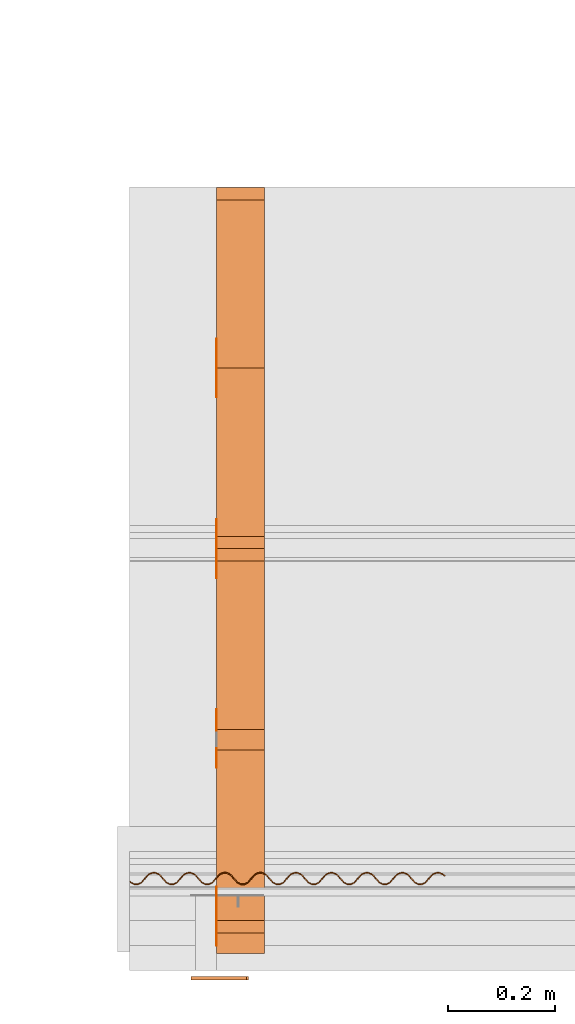
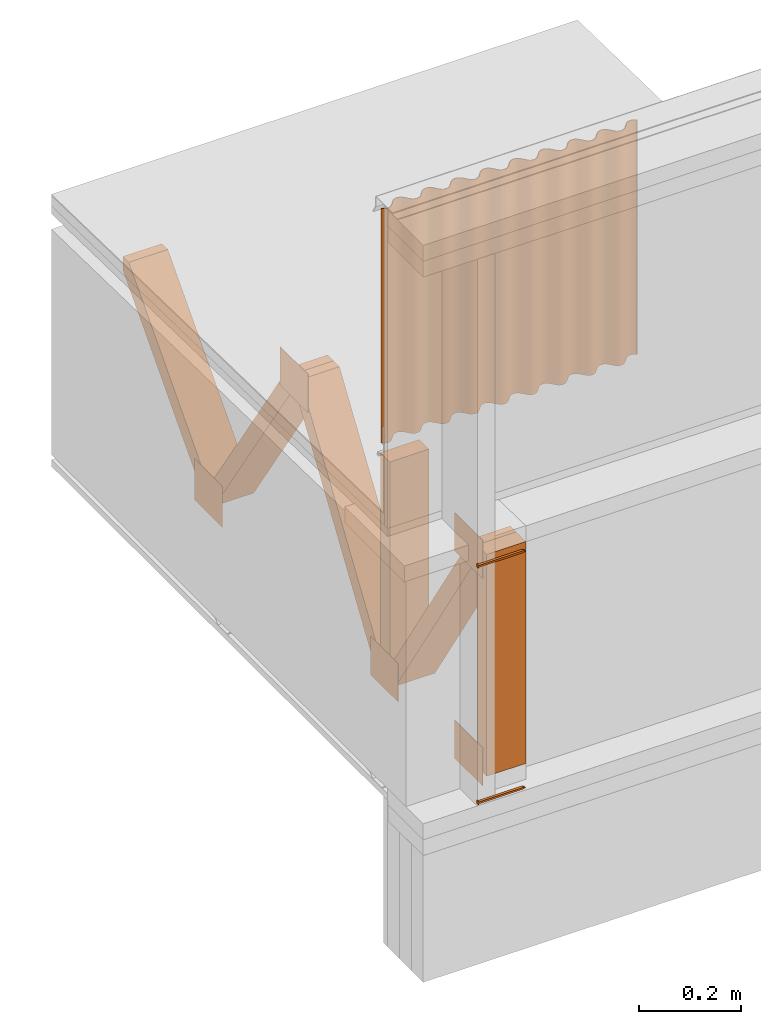
# One storey, part 14 of 22: 14 proxies.
"""IFC2X3 building model written with IfcOpenShell, lengths in feet."""

from ifc_helpers import new_model, entity, si_unit, converted_unit, frame, frame_2d, origin_with_axes, place, context, subcontext, project, spatial, polyline, rectangle, outline, extrude, source, transform, mapped, type_object, type_shapes, element, save


model = new_model("IFC2X3")

# Units and contexts
model_context = context("Model", 3, precision=1e-05)
plan_context = context("Plan", 2, precision=1e-05, world=frame_2d((0.0, 0.0, 0.0), x_axis=(1.0, 0.0, 0.0)))
body_context_1 = subcontext(model_context, "Body", "Model", "MODEL_VIEW")
body_context_2 = subcontext(model_context, "Body", "Model", "MODEL_VIEW")
ifc_project = project(units=[converted_unit("VOLUMEUNIT", "cubic foot", entity("IfcReal", 0.0283168467116885), si_unit("VOLUMEUNIT", "CUBIC_METRE"), dimensions=[3, 0, 0, 0, 0, 0, 0]), converted_unit("AREAUNIT", "square foot", entity("IfcReal", 0.09290304), si_unit("AREAUNIT", "SQUARE_METRE"), dimensions=[2, 0, 0, 0, 0, 0, 0]), converted_unit("LENGTHUNIT", "foot", entity("IfcReal", 0.3048), si_unit("LENGTHUNIT", "METRE"), dimensions=[1, 0, 0, 0, 0, 0, 0])], contexts=[model_context, plan_context])

# Site, building, storey
site_placement = place(None, origin_with_axes())
site = spatial("IfcSite", under=ifc_project, at=site_placement, CompositionType="ELEMENT")
building_placement = place(site_placement, origin_with_axes())
building = spatial("IfcBuilding", under=site, at=building_placement, Name="Building", CompositionType="ELEMENT")
storey_placement = place(building_placement, origin_with_axes())
storey = spatial("IfcBuildingStorey", under=building, at=storey_placement, Name="Storey", CompositionType="ELEMENT")

# Proxies
building_element_proxy_type = type_object("IfcBuildingElementProxyType", PredefinedType="NOTDEFINED")
shared_shape = source(origin_with_axes(), body_context_1, "Body", "SweptSolid", [
    extrude(outline(polyline([(0.118784633345335, 3.75537964679768e-09), (0.115601355674386, 0.0273151472308661), (0.10877257344995, 0.0265193217020883), (0.109568402034248, 0.019690537949892), (-0.221524240933065, -0.0188947170043946), (-0.234386001241802, -0.0273151411198256), (-0.219932583764469, -0.0325522875643074), (0.111160034758682, 0.0060329681538593), (0.111955851120899, -0.000795817269324606), (0.118784633345335, 3.75537964679768e-09)])), frame((0.111111134212474, 6.6839505642105e-10, -0.0200000086804153), z_axis=(-4.82754742847646e-08, 0.0, -1.0), x_axis=(-0.993277668952942, -0.115755714476109, 5.14463884826455e-08)), (-8.28972535060757e-09, 7.11323480118153e-08, -0.999999940395355), 0.0199999997321789),
])
type_shapes(building_element_proxy_type, [shared_shape])
for number, where, z_axis, x_axis in (
    (1, (1675.26345240475, 0.883739177636274, -61.5758282618886), (-3.25841426729312e-07, 1.0, -1.94707183709397e-07), (1.0, 3.25841369885893e-07, -3.25841369885893e-07)),
    (2, (1675.26345240475, 0.883739177636274, -59.7100558243399), (-3.25841426729312e-07, 1.0, -1.94707183709397e-07), (1.0, 3.25841369885893e-07, -3.25841369885893e-07)),
):
    element("IfcBuildingElementProxy", number, at=place(storey_placement, frame(where, z_axis=z_axis, x_axis=x_axis)), inside=storey, type_object=building_element_proxy_type, context=body_context_1, shape_type="MappedRepresentation", body=[
        mapped(shared_shape, transform((0.0, 0.0, 0.0), x_axis=(1.0, 0.0, 0.0), y_axis=(0.0, 1.0, 0.0), z_axis=(0.0, 0.0, 1.0), scale=1.0)),
    ])
proxy_1_placement = place(storey_placement, frame((1675.4142380762, 4.92389902980935, -61.9758708583401), z_axis=(0.0, 0.0, 1.0), x_axis=(-4.37113882867379e-08, -1.0, 0.0)))
element("IfcBuildingElementProxy", 3, at=proxy_1_placement, inside=storey, Name="Generic Models 855:Generic Models 1", context=body_context_1, shape_type="SweptSolid", body=[
    extrude(outline(polyline([(-0.83499908290823, -0.554330822989697), (-0.726033657241681, -0.554330822989697), (0.834998691801637, 0.478032575504673), (0.834998691801637, 0.55433121409629), (0.726033461688385, 0.55433121409629), (-0.834998985131582, -0.478032379951377), (-0.83499908290823, -0.554330822989697)])), frame((1.96849052205173, 2.46049200261872e-07, 1.29333396596233), z_axis=(0.0, -1.0, 0.0), x_axis=(0.0, 0.0, 1.0)), (0.0, 0.0, -1.0), 0.291666664589754),
])
proxy_2_placement = place(storey_placement, frame((1675.4142380762, 4.92389902980935, -61.9758708583401), z_axis=(0.0, 0.0, 1.0), x_axis=(-4.37113882867379e-08, -1.0, 0.0)))
element("IfcBuildingElementProxy", 4, at=proxy_2_placement, inside=storey, Name="Generic Models 855:Generic Models 1", context=body_context_1, shape_type="SweptSolid", body=[
    extrude(outline(polyline([(-0.960161308134635, -0.06187384522806), (0.911361178544563, -0.0618737718955738), (1.0022490708221, -0.00176660403648386), (0.960161308134635, 0.0618739185605462), (-0.911361374097859, 0.0618737474514118), (-1.00224897304545, 0.00176672625729418), (-0.960161308134635, -0.06187384522806)])), frame((0.859770405636685, 2.21605038198473e-07, 1.29333445484557), z_axis=(1.26844657000191e-09, -1.0, -3.13384731498445e-08), x_axis=(-0.551616966724396, 2.54396539389745e-08, -0.834097564220428)), (-1.42177441375679e-07, 1.83448563007005e-08, -1.0), 0.291666664589757),
])
proxy_3_placement = place(storey_placement, frame((1675.4142380762, 7.14122936168681, -61.9758708583401), z_axis=(0.0, 0.0, 1.0), x_axis=(-4.37113882867379e-08, -1.0, 0.0)))
element("IfcBuildingElementProxy", 5, at=proxy_3_placement, inside=storey, Name="Generic Models 855:Generic Models 1", context=body_context_1, shape_type="SweptSolid", body=[
    extrude(outline(polyline([(-0.554331018542993, -0.624998895514981), (-0.478032379951377, -0.624998895514981), (0.554331018542993, 0.516033567625081), (0.554331018542993, 0.62499899329163), (0.478032575504673, 0.624998944403305), (-0.554331018542993, -0.516033665401729), (-0.554331018542993, -0.624998895514981)])), frame((1.96849032649844, 0.291666910638959, 1.08333377856908), z_axis=(0.0, 1.0, 0.0), x_axis=(1.0, 0.0, 0.0)), (0.0, -3.35234233261872e-07, -1.0), 0.291666664589771),
])
proxy_4_placement = place(storey_placement, frame((1675.4142380762, 6.03256419574808, -61.8508731912127), z_axis=(0.0, 0.0, 1.0), x_axis=(-4.37113882867379e-08, -1.0, 0.0)))
element("IfcBuildingElementProxy", 6, at=proxy_4_placement, inside=storey, Name="Generic Models 855:Generic Models 1", context=body_context_1, shape_type="SweptSolid", body=[
    extrude(rectangle(XDim=0.124999233345449, YDim=0.291669311091376, at=frame_2d((0.0, 0.0, 0.0))), frame((3.69392433191535, 0.145834848636717, 0.333333109307477), z_axis=(-1.56443593368749e-06, 0.0, -1.0), x_axis=(0.999999940395355, 0.0, -1.56443593368749e-06)), (-9.58482360147173e-07, 0.0, -1.0), 1.72116860376226),
])
proxy_5_placement = place(storey_placement, frame((1675.4142380762, 4.78252494741925, -61.8508731912127), z_axis=(0.0, 0.0, 1.0), x_axis=(-4.37113882867379e-08, -1.0, 0.0)))
element("IfcBuildingElementProxy", 7, at=proxy_5_placement, inside=storey, Name="Generic Models 855:Generic Models 1", context=body_context_1, shape_type="SweptSolid", body=[
    extrude(rectangle(XDim=0.124999233345449, YDim=0.291669311091376, at=frame_2d((0.0, 0.0, 0.0))), frame((3.69392433191535, 0.145834848636717, 0.333333109307477), z_axis=(-1.56443593368749e-06, 0.0, -1.0), x_axis=(-0.999999940395355, 0.0, 1.56443593368749e-06)), (9.68473727880337e-07, 0.0, -1.0), 1.75002364560732),
])
proxy_6_placement = place(storey_placement, frame((1675.41143462414, 4.67839672809511, -61.4758739321251), z_axis=(0.0, 0.0, 1.0), x_axis=(-4.37113882867379e-08, -1.0, 0.0)))
element("IfcBuildingElementProxy", 8, at=proxy_6_placement, inside=storey, Name="Generic Models 852:Generic Models 1", context=body_context_1, shape_type="SweptSolid", body=[
    extrude(rectangle(XDim=0.360930176725411, YDim=0.00277022707595213, at=frame_2d((0.0, 0.0, 0.0))), frame((3.42311743363308, 0.00138511354766121, 1.4904025071875), z_axis=(0.0, 0.0, -1.0), x_axis=(1.0, 0.0, 0.0)), (0.0, 0.0, -1.0), 0.301264218204712),
])
proxy_7_placement = place(storey_placement, frame((1675.41143462414, 4.79884504333256, -61.6217035008228), z_axis=(0.0, 0.0, 1.0), x_axis=(-4.37113882867379e-08, -1.0, 0.0)))
element("IfcBuildingElementProxy", 9, at=proxy_7_placement, inside=storey, Name="Generic Models 852:Generic Models 1", context=body_context_1, shape_type="SweptSolid", body=[
    extrude(rectangle(XDim=0.360930148950862, YDim=0.00277022707595213, at=frame_2d((0.0, 0.0, 0.0))), frame((0.180465076363149, 0.00138511354766121, 0.0), z_axis=(0.0, 0.0, -1.0), x_axis=(-1.0, 0.0, 0.0)), (0.0, 0.0, -1.0), 0.322097519461289),
])
proxy_8_placement = place(storey_placement, frame((1675.41143462414, 4.74287612544583, -61.6217035008228), z_axis=(0.0, 0.0, 1.0), x_axis=(-4.37113882867379e-08, -1.0, 0.0)))
element("IfcBuildingElementProxy", 10, at=proxy_8_placement, inside=storey, Name="Generic Models 852:Generic Models 1", context=body_context_1, shape_type="SweptSolid", body=[
    extrude(rectangle(XDim=0.360929982303518, YDim=0.00277022707595213, at=frame_2d((0.0, 0.0, 0.0))), frame((2.39778886942726, 0.00138511354766121, 0.0), z_axis=(0.0, 0.0, -1.0), x_axis=(1.0, 0.0, 0.0)), (0.0, 0.0, -1.0), 0.301264184929359),
])
proxy_9_placement = place(storey_placement, frame((1675.41143462414, 4.79884504333256, -61.5350405375163), z_axis=(0.0, 0.0, 1.0), x_axis=(-4.37113882867379e-08, -1.0, 0.0)))
element("IfcBuildingElementProxy", 11, at=proxy_9_placement, inside=storey, Name="Generic Models 852:Generic Models 1", context=body_context_1, shape_type="SweptSolid", body=[
    extrude(rectangle(XDim=0.360930176725411, YDim=0.00277022707595213, at=frame_2d((0.0, 0.0, 0.0))), frame((1.28912702789457, 0.00138511354766121, 1.4904025071875), z_axis=(0.0, 0.0, -1.0), x_axis=(1.0, 0.0, 0.0)), (0.0, 0.0, -1.0), 0.301264218204712),
])
proxy_10_placement = place(storey_placement, frame((1675.41143462414, 3.65313426090351, -61.6217035008228), z_axis=(0.0, 0.0, 1.0), x_axis=(-4.37113882867379e-08, -1.0, 0.0)))
element("IfcBuildingElementProxy", 12, at=proxy_10_placement, inside=storey, Name="Generic Models 852:Generic Models 1", context=body_context_1, shape_type="SweptSolid", body=[
    extrude(rectangle(XDim=0.360929982303518, YDim=0.00277022707595213, at=frame_2d((0.0, 0.0, 0.0))), frame((2.39778886942726, 0.00138511354766121, 0.0), z_axis=(0.0, 0.0, -1.0), x_axis=(-1.0, 0.0, 0.0)), (0.0, 0.0, -1.0), 0.301264184929359),
])
proxy_11_placement = place(storey_placement, frame((1675.4142380762, 2.70656889348518, -61.9758708583401), z_axis=(0.0, 0.0, 1.0), x_axis=(-4.37113882867379e-08, -1.0, 0.0)))
element("IfcBuildingElementProxy", 13, at=proxy_11_placement, inside=storey, Name="Generic Models 855:Generic Models 1", context=body_context_1, shape_type="SweptSolid", body=[
    extrude(outline(polyline([(-0.999140653397467, -0.0614843519497418), (0.948410510547518, -0.0614845475030383), (1.04022757431341, -0.00280711868303654), (0.999140848950764, 0.0614841563964453), (-0.948410314994221, 0.0614846208355245), (-1.04022737876011, 0.0028069475739021), (-0.999140653397467, -0.0614843519497418)])), frame((0.99294943603005, 2.20078280475601e-07, 1.33334553930077), z_axis=(3.70475894406752e-09, -1.0, -2.96324760284961e-08), x_axis=(0.538498640060425, -2.29741878854384e-08, 0.842626452445984)), (4.79877144243801e-07, -3.54313016259766e-07, -1.0), 0.291666664589806),
])
proxy_12_placement = place(storey_placement, frame((1674.88038070559, 1.46614148078628, -57.0275777281113), z_axis=(-8.02678641775856e-07, 5.64259664770361e-07, 1.0), x_axis=(3.13916473260178e-07, -1.0, 5.64259892144037e-07)))
element("IfcBuildingElementProxy", 14, at=proxy_12_placement, inside=storey, Name="Generic Models 1:Generic Models 1", context=body_context_2, shape_type="SweptSolid", body=[
    extrude(outline(polyline([(0.135952978348482, -4.94134916711276e-09), (0.1248598387196, -0.00656200398683665), (0.0891126411187211, -0.0342203480169529), (0.0780221842366254, -0.0406805550547566), (0.0656541837794887, -0.0443130033701815), (0.0527797858389657, -0.0447688106046574), (0.0401728589752606, -0.0421088763324451), (0.0285739513001652, -0.036489438470893), (0.0187218203905999, -0.0281687373701199), (0.0112109497957068, -0.017783858170464), (-0.0103215581255909, 0.0219600027050637), (-0.017823781598154, 0.0324454115767257), (-0.0276493753142792, 0.0408628382267836), (-0.0392359661872149, 0.0464796636185152), (-0.0518613758929602, 0.0491435059011374), (-0.0647420193168904, 0.0486890492066154), (-0.0771181780131157, 0.0449559764980566), (-0.0882172759065008, 0.0383952703434495), (-0.123976610033844, 0.0107394448259058), (-0.135060998652707, 0.0042779663097348), (-0.147422692516032, 0.000644179533209451), (-0.160290979416039, 0.000187101178434971), (-0.172910278081268, 0.00284965095211681), (-0.184509130756999, 0.00846906417853681), (-0.194355202569893, 0.0167884888357221), (-0.201872185733062, 0.0271746880201295), (-0.223404632543954, 0.0669185213959749), (-0.230913121360806, 0.0774052502523883), (-0.240738525634676, 0.0858226219030816), (-0.252319142965507, 0.0914381731428656), (-0.264944454894604, 0.0941020001478865), (-0.277824963875643, 0.0936475098426417), (-0.2902012631258, 0.0899144829668867), (-0.301300257131496, 0.0833537615346783), (-0.337065855075368, 0.0556992498908456), (-0.348144291540769, 0.0492365067712278), (-0.360505924293688, 0.045602744582092), (-0.373374064528723, 0.0451456173628647), (-0.385999523122792, 0.0478094627010071), (-0.397579993788652, 0.0534249894966291), (-0.407438495457955, 0.0617470228042346), (-0.414949233137716, 0.0721319233925324), (-0.436487864321611, 0.111877067586568), (-0.443996328694301, 0.122363784220901), (-0.453815597483492, 0.130779872553086), (-0.465408534672004, 0.136398020985089), (-0.478015513479553, 0.139057973590423), (-0.490895924683944, 0.138603458841016), (-0.503284421570971, 0.134872998602278), (-0.514383440020829, 0.128312295503191), (-0.550143049144995, 0.100656524985012), (-0.561221338945424, 0.094193757421232), (-0.573583045030829, 0.0905599677324139), (-0.586463407346896, 0.0901054346498855), (-0.599082706012125, 0.0927680027805601), (-0.610669483271796, 0.0983848495609335), (-0.620515542862609, 0.106704255121117), (-0.628044735884729, 0.117093023998061), (-0.649571047210944, 0.156835589333), (-0.657073449431442, 0.167321022648824), (-0.666904940301665, 0.175739689840107), (-0.678485557632496, 0.181355259413012), (-0.691092634216694, 0.184015224240427), (-0.7039791564616, 0.183561992809528), (-0.716373764389143, 0.179832840333461), (-0.727466574021837, 0.173270805027541), (-0.763220072105488, 0.145613751190854), (-0.774298459682565, 0.139150995849155), (-0.786666227920162, 0.135518495589886), (-0.799546639124552, 0.135063968618398), (-0.812159826749266, 0.137725228986402), (-0.823752617272805, 0.143343365196324), (-0.833598627975294, 0.15166278908963), (-0.841121758845222, 0.162050262425985), (-0.862660292252468, 0.201795406620021), (-0.870162694472966, 0.212280852157926), (-0.879975852221642, 0.22069563272744), (-0.891562580592989, 0.226312461174692), (-0.904181928146543, 0.228975041527448), (-0.917062339350933, 0.228520526778041), (-0.929456898390152, 0.224791349857811), (-0.94054359698233, 0.218228043455464), (-0.937370744746501, 0.214079453602551), (-0.927388433396347, 0.219954852396109), (-0.916226251231717, 0.223330053405499), (-0.90461146096232, 0.223846949656492), (-0.893259689876727, 0.221451837325034), (-0.882837676939376, 0.216285417007962), (-0.874002970109774, 0.208691006961457), (-0.867232817208047, 0.199281006777693), (-0.845665146359621, 0.159734385845855), (-0.837418174962672, 0.148170891650549), (-0.826593908894406, 0.139031133900477), (-0.813865393713078, 0.132764078520258), (-0.799990789549244, 0.129836670115707), (-0.785815326638735, 0.13042725329324), (-0.772215279303198, 0.134413705019187), (-0.760005615905827, 0.141661056852716), (-0.724281401928328, 0.169119624093449), (-0.71430520161869, 0.174996306205515), (-0.703142921677412, 0.178371494992824), (-0.691534438001828, 0.17888973567273), (-0.68018261802791, 0.176494611119191), (-0.66975468960334, 0.171326919705693), (-0.660919640555469, 0.163732460770864), (-0.654149536542066, 0.154322472809181), (-0.632581914581965, 0.114775827433181), (-0.624341054225531, 0.103213641000545), (-0.613504517187909, 0.0940713043913754), (-0.600782161935421, 0.087805538440705), (-0.586913815477076, 0.0848794377988248), (-0.572732192637726, 0.0854687193247277), (-0.559132145302189, 0.089455183272756), (-0.546928690721982, 0.0967038245358336), (-0.511198121262348, 0.124161065680774), (-0.501222018729358, 0.130037760014922), (-0.490071911980787, 0.133415552105491), (-0.478457415041335, 0.133932485022726), (-0.467087115280897, 0.131533461625338), (-0.456677617754523, 0.126369669055688), (-0.447842519818328, 0.118775185676697), (-0.441066402541058, 0.109363938840668), (-0.419504891621472, 0.0698186073383791), (-0.411257920224523, 0.0582551314761945), (-0.400427567559903, 0.0491140873520941), (-0.387711225571282, 0.0428495986088915), (-0.373830510366933, 0.0399208885527111), (-0.359655096344748, 0.0405114778412843), (-0.346048913524533, 0.044496643193203), (-0.333845312279353, 0.051745266123159), (-0.298121122746017, 0.0792038394749321), (-0.288151057921057, 0.0850818293496692), (-0.276982666939262, 0.0884557287074293), (-0.265368072223163, 0.0889726677357055), (-0.254010092320405, 0.0865762354194961), (-0.243594385976866, 0.0814111411982165), (-0.234765594634484, 0.0738179839150173), (-0.227989355136403, 0.0644067248569073), (-0.206427819772655, 0.0248613841880572), (-0.198174639558542, 0.0132965761190403), (-0.187350446822762, 0.00415683020910938), (-0.174627944905301, -0.00210896648773361), (-0.160753536294764, -0.00503632008388951), (-0.146571766790443, -0.00444708133527026), (-0.132965583970228, -0.000461903474815532), (-0.120768435983833, 0.0067880735280398), (-0.0850440936744839, 0.0342466346577318), (-0.0750617639912082, 0.0401219998405674), (-0.0638995390492944, 0.0434972130720384), (-0.0522911470393183, 0.044015472085066), (-0.0409270560960444, 0.0416177472837876), (-0.03051115725473, 0.036452607229704), (-0.0216701377202754, 0.0288568863650085), (-0.0149061691915504, 0.0194481679719929), (0.00666142068558869, -0.0200984300434433), (0.0149085479140712, -0.0316619486829114), (0.0257323419044572, -0.0408016178228958), (0.0384552379840315, -0.047067499883336), (0.0523294510412717, -0.0499948349554004), (0.0665175271394059, -0.0494068917473705), (0.0801053340607897, -0.045417855051285), (0.092314740794459, -0.0381704482183916), (0.128038887550512, -0.0107118832692993), (0.138021321121476, -0.00483650319080242), (0.149183637728998, -0.00146130600081282), (0.160798305777584, -0.00094434243288952), (0.172150162417745, -0.00333949076219552), (0.182571735360178, -0.00850587326720396), (0.191406784408049, -0.0161003490073944), (0.198177022864343, -0.0255103278025163), (0.21974470593485, -0.0650569640119558), (0.227991726220123, -0.0766204582072618), (0.238815918955903, -0.0857602281794148), (0.251538225320068, -0.0920259696859231), (0.265412731707253, -0.0949533719794331), (0.279600514475442, -0.0943653859941196), (0.293188510839082, -0.0903763492980341), (0.305404089723672, -0.0831302991161353), (0.341128425921981, -0.0556717257643622), (0.351104601787457, -0.0497950894850993), (0.36226693061706, -0.0464198609760271), (0.373875316515995, -0.0459016141850804), (0.385239407459269, -0.0482993267642779), (0.395655211579455, -0.0534644668183615), (0.404490260627326, -0.0610589135311094), (0.411260120199108, -0.0704688709375896), (0.432827888824183, -0.11001552242463), (0.44107471355616, -0.121578967731612), (0.451899126289398, -0.130718737703765), (0.464621481541886, -0.136984521987557), (0.478495987929071, -0.139911905947946), (0.492677659656745, -0.139322618311002), (0.50627140039847, -0.135334871044466), (0.518481308237461, -0.12808755587718), (0.554211633255475, -0.100630290288077), (0.564187980230086, -0.0947536570643346), (0.575323371593095, -0.0914750593834192), (0.586952339476488, -0.0908588587240441), (0.598322492571953, -0.0932578271220675), (0.608738198915492, -0.0984229580095903), (0.61757334574001, -0.10601742305546), (0.624343400865089, -0.115427398795062), (0.645905009561323, -0.154972748630472), (0.654158189775437, -0.16653756281053), (0.66497590480827, -0.175675951687526), (0.677704859984515, -0.181943104844394), (0.691579659701645, -0.184870525471025), (0.705754633728913, -0.184279868961006), (0.719360645439994, -0.180294663887324), (0.731564393350146, -0.17304606540153), (0.76728855843932, -0.145587473716636), (0.777258549931794, -0.13970949606398), (0.788406750035724, -0.136433611685053), (0.800041780071309, -0.135818657677943), (0.811399515532446, -0.138215077772072), (0.821794737668175, -0.143478199194266), (0.830650662030448, -0.150974710371707), (0.837420423825582, -0.160384612778823), (0.858988094674008, -0.199931270376904), (0.867241225999797, -0.211496047890718), (0.878065492068063, -0.220635817862871), (0.890787896208876, -0.22690156548042), (0.904656535997165, -0.229827702788543), (0.918837963283218, -0.229238427373681), (0.932443779441002, -0.225253148967513), (0.944641220757342, -0.218003254941129), (0.941433462258086, -0.214051978364391), (0.930348621422224, -0.220513401499258), (0.917986817560171, -0.224147099522468), (0.905113055167861, -0.224603007589112), (0.892499280883258, -0.221941673888622), (0.880907174796257, -0.216323647677429), (0.871054710834984, -0.208002903799372), (0.863537544340599, -0.197616652671121), (0.842005659745434, -0.157872926238484), (0.834496999819448, -0.14738618515999), (0.824665460060901, -0.138967481302464), (0.813096478151211, -0.13335441725617), (0.800477228374306, -0.130691861347576), (0.787591097235993, -0.13114515388888), (0.775202502572317, -0.134875626349699), (0.764109595162975, -0.141437600545214), (0.728350132703781, -0.169093432173798), (0.717272038456649, -0.175556199737578), (0.704910185706271, -0.179189958871193), (0.692035983319045, -0.179645805827432), (0.679416537988843, -0.176983237696758), (0.667829467399227, -0.171366299250777), (0.657971576833975, -0.16304436983086), (0.650454361451267, -0.152658118702608), (0.628921645754591, -0.112914221160837), (0.621413425823522, -0.102427583970032), (0.611588241547111, -0.09401023065246), (0.600007330886335, -0.0883945877470682), (0.58739424103827, -0.0857333701563476), (0.574513976498852, -0.086187903238876), (0.562119319682985, -0.0899170618259844), (0.551026118943697, -0.096479005466296), (0.515266803149476, -0.124134824872799), (0.504188562237372, -0.130597641324903), (0.491832967192482, -0.134232695999108), (0.478952409323119, -0.134687186304353), (0.466326901840726, -0.132023322633089), (0.454740320134351, -0.126406481963756), (0.44489416276689, -0.118087058070451), (0.437371178561934, -0.107699609178258), (0.415838658418555, -0.067955736080649), (0.40833652508384, -0.0574703455421086), (0.398517280738811, -0.049054296931687), (0.386930601255787, -0.0434374226516313), (0.374311155925586, -0.0407748667430377), (0.361430695832871, -0.041229363159323), (0.349035965684518, -0.0449584942467491), (0.337943033831013, -0.0515205020529861), (0.302183595815981, -0.0791763092374082), (0.291105257127229, -0.0856390706901475), (0.278749686526501, -0.0892741436974739), (0.26586903088049, -0.0897286340027187), (0.253249976656881, -0.0870661086493277), (0.241657235021666, -0.0814480029946081), (0.231817017585587, -0.0731298074204465), (0.224288166781736, -0.0627411240980694), (0.202761525459333, -0.0229985022360063), (0.195259404346699, -0.0125131178085064), (0.185434097849478, -0.00409576563675475), (0.173841062884318, 0.00152242729126224), (0.161227875259605, 0.00418368173919599), (0.14834741516689, 0.00372919563529157), (0.135952978348482, -4.94134916711276e-09)])), frame((-0.0194551742799443, 0.965128166312621, -1.94056746684347), z_axis=(-0.000177217269083485, 5.31205296283588e-06, -1.0), x_axis=(0.206445381045341, 0.978458166122437, -1.72606778505724e-05)), (7.37670270609669e-05, -0.000142849195981398, -1.0), 1.85124269574771),
])

save(model, "model.ifc")
